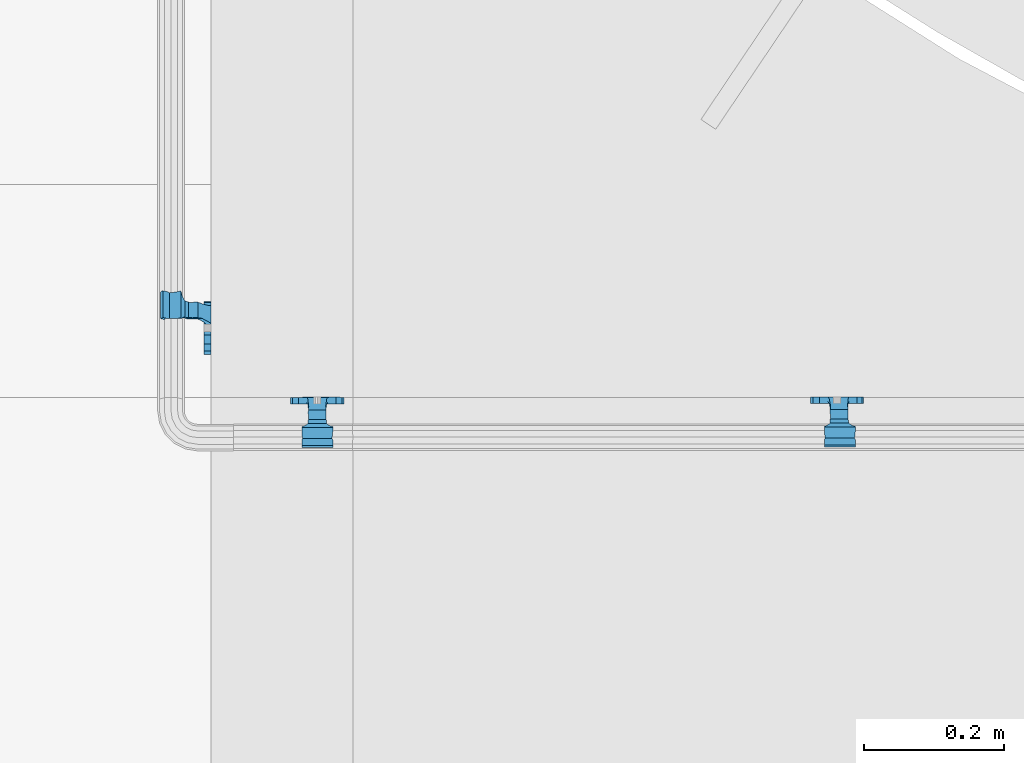
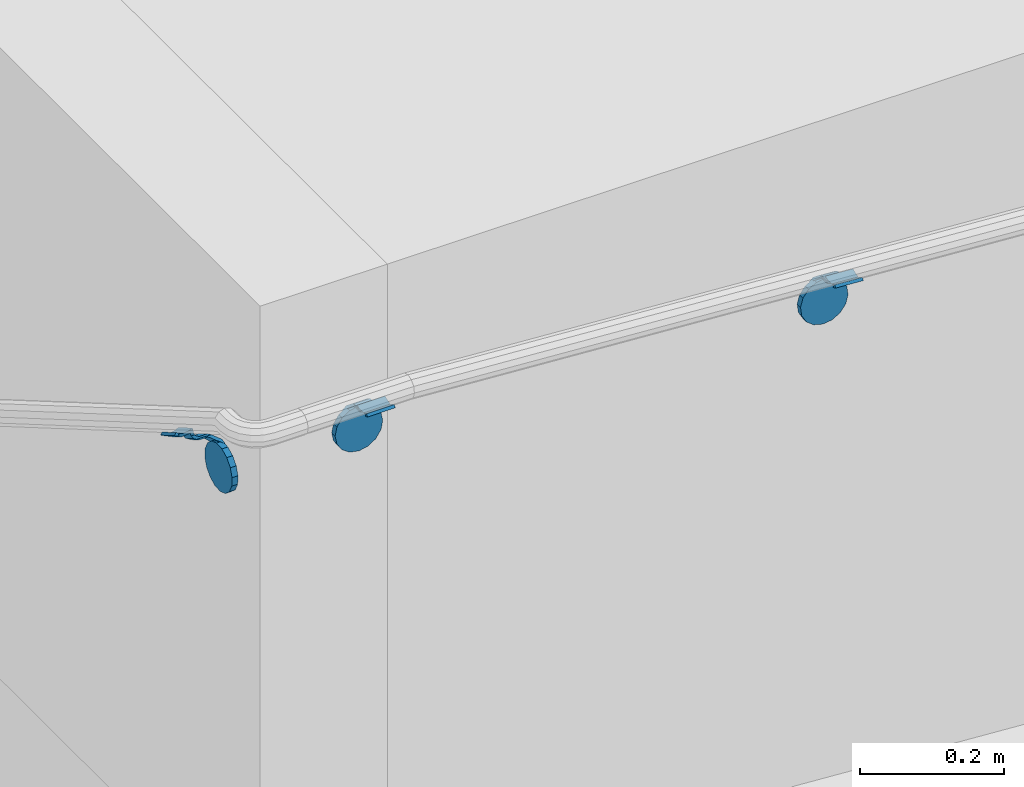
# One storey, part 458 of 975: 3 beams.
"""IFC2X3 building model written with IfcOpenShell, lengths in millimetres."""

from ifc_helpers import new_model, si_unit, frame, origin_with_axes, place, context, subcontext, project, spatial, faceted_brep, material, type_object, element, save


model = new_model("IFC2X3")

# Units and contexts
model_context = context("Model", 3, precision=1e-05, world=origin_with_axes())
body_context = subcontext(model_context, "Body", "Model", "MODEL_VIEW")
ifc_project = project(units=[si_unit("LENGTHUNIT", "METRE", prefix="MILLI"), si_unit("AREAUNIT", "SQUARE_METRE"), si_unit("VOLUMEUNIT", "CUBIC_METRE"), si_unit("MASSUNIT", "GRAM", prefix="KILO"), si_unit("TIMEUNIT", "SECOND"), si_unit("PLANEANGLEUNIT", "RADIAN"), si_unit("SOLIDANGLEUNIT", "STERADIAN"), si_unit("THERMODYNAMICTEMPERATUREUNIT", "DEGREE_CELSIUS"), si_unit("LUMINOUSINTENSITYUNIT", "LUMEN")], contexts=[model_context])

# Site, building, storey
site_placement = place(None, origin_with_axes())
site = spatial("IfcSite", under=ifc_project, at=site_placement, CompositionType="ELEMENT")
building_placement = place(site_placement, origin_with_axes())
building = spatial("IfcBuilding", under=site, at=building_placement, Name="Undefined", CompositionType="ELEMENT")
storey_placement = place(building_placement, origin_with_axes())
storey = spatial("IfcBuildingStorey", under=building, at=storey_placement, Name="Undefined", CompositionType="ELEMENT", Elevation=0.0)

# Beams
ifc_material = material(Name="STEEL/A36")
beam_type = type_object("IfcBeamType", PredefinedType="NOTDEFINED")
beam_1_placement = place(storey_placement, frame((31940.502546356, -314.324788467751, 1879.62058813558), z_axis=(0.999999955697456, 0.000267209998025066, -0.000131163650922872), x_axis=(-0.000267362000091947, 0.999999306156933, -0.00114725900017339)))
element("IfcBeam", 1, at=beam_1_placement, inside=storey, type_object=beam_type, material=ifc_material, Name="WALL BRACKET", context=body_context, shape_type="Brep", body=[
    faceted_brep([(-1.09139364212751e-11, -35.1998101886752, 14.5802387730655), (0.0, -26.940768363208, 26.9407683632162), (1.2732925824821e-11, -14.5802387731151, 35.1998101887366), (0.0, 0.0, 38.0999984741211), (3.27418092638254e-11, 14.5802387730973, 35.1998101888166), (3.45607986673713e-11, 26.9407683631939, 26.9407683633472), (3.27418092638254e-11, 35.1998101886679, 14.5802387732328), (2.36468622460961e-11, 38.0999999999908, 8.73114913702011e-11), (1.45519152283669e-11, 35.1998101886752, -14.5802387730655), (1.81898940354586e-12, 26.9407683632071, -26.9407683632162), (-1.09139364212751e-11, 14.5802387731146, -35.1998101887511), (0.0, 0.0, -38.0999984741211), (-2.91038304567337e-11, -14.5802387730978, -35.1998101888239), (-3.27418092638254e-11, -26.9407683631948, -26.9407683633617), (-3.09228198602796e-11, -35.1998101886688, -14.5802387732401), (-2.36468622460961e-11, -38.0999999999917, -9.45874489843845e-11), (9.52499999999407, 35.4440469783465, 13.3523775149006), (9.52500000001783, 38.099999999989, 1.23691279441118e-10), (5.45819490078651, 35.1998101886775, 14.58023877304), (5.15915812204861, 35.4440469814256, 13.3523774994246), (5.15916016817869, 35.4440461871586, -13.3523814925829), (5.45819607316758, 35.1998101886757, -14.5802387731565), (9.52499999563867, 35.4440461839649, -13.352381508641), (9.52499999999338, 33.7468954266617, -16.754679378646), (9.52499999999418, 26.9407683632057, -26.9407683631944), (7.23710514487385, 33.7468954167059, -16.7546793935435), (9.52499999997963, 14.5802387731133, -35.199810188722), (9.52499999996871, 7.73070496506989e-12, -38.1000000000931), (9.52499999996326, -14.5802387730996, -35.1998101888021), (9.52499999995962, -26.9407683631966, -26.9407683633399), (9.5249999999578, -35.1998101886768, -14.5802387731064), (9.52499999997235, -38.0999999999935, -7.27595761418343e-11), (9.52499999988504, -35.1998101886779, 14.5802387731401), (9.52499999999418, -26.9407683632098, 26.940768363238), (9.52500000000691, -14.5802387731169, 35.1998101887584), (9.52500000001783, -1.13686837721616e-11, 38.1000000001295), (9.5250000000251, 14.580238773096, 35.1998101888312), (9.52500000002692, 26.9407683631925, 26.9407683633617), (7.23710629084189, 33.7468933804012, 16.7546824409801), (9.52500001802099, 33.74689339, 16.7546824266137), (4.12737783423069, 36.2867482851609, 11.6630037101459), (9.52500001480979, 36.2867482910076, 11.6630037099276), (1.9072828969438, 38.0999998001848, -4.3824766180478e-06), (9.43529109937867, 38.0999998083389, -4.38277129433118e-06), (4.12738199474541, 36.2867456530334, -11.6630120660157), (9.52499999713365, 36.2867456588801, -11.6630120662267), (9.52499998931302, 31.8782691818908, -20.5007361535354), (1.90728516843444, 38.0999984362613, -14.9620414784949), (9.43529504267332, 38.0999984471014, -14.9620414798228), (9.52499998867484, 31.8782692100656, -21.3428983101403), (-0.974480980704527, 40.4536660864392, -13.6176374922397), (6.55352889353486, 40.4536660972792, -13.617637493564), (-3.23293929398841, 48.4467136552532, -12.2071016444133), (-3.86099316375032, 48.9596734302611, -12.3332393299024), (-3.86099415506237, 48.9596734359397, 12.1506042690053), (-3.23294234398753, 48.4467162038179, 12.0244673261113), (6.55352388489973, 40.4536689343606, 13.4350048968336), (9.4352891744017, 38.1000015670843, 14.7794093900302), (-8.88876894391092, 51.462646060533, -12.9487245784876), (-14.5044020842531, 51.5524567377918, -12.9708091785214), (-14.5044031272276, 51.5524567437842, 12.788173508583), (-8.88876998507754, 51.4626460665079, 12.7660889411018), (-16.4483770195459, 51.1442726592504, -12.8704360163174), (-16.4483780543928, 51.1442726651987, 12.6878004343525), (-22.5793182144077, 51.3711360271759, -12.9262221073186), (-22.5793192537777, 51.3711360331463, 12.7435864607032), (-27.8885284154861, 54.4455780358899, -13.6822326528272), (-27.8885295160832, 54.4455780422152, 13.4995963000001), (-28.6196515649072, 55.6169452716154, -13.9702738582564), (-31.1370083013608, 59.6501226213948, -17.5950925222933), (-31.1370097188383, 59.6501226295447, 17.4124524185645), (-28.6196545294583, 55.616948227025, 13.7876379643458), (-33.6296792490059, 67.324805151891, -22.2250062266612), (-32.8101722890036, 64.8016260361878, -22.2250061928717), (-39.3161821982224, 64.9509398614337, -22.2250064563596), (-33.6296810489844, 67.3248051619378, 22.2249937734341), (-39.3127719838823, 64.95236112884, 22.2249935438595), (-32.8101756191698, 64.8016307577993, 22.2249938072164), (-49.8281982508399, 63.7590297560901, -21.2879733583577), (-49.8281999673757, 63.7590297658239, 21.1053316176076), (-62.537662592724, 64.8016282183019, -22.2250073966388), (-62.5376643923654, 64.8016282284259, 22.2249926034456), (-59.3629825026719, 68.3509998487543, 22.2249927311568), (-59.3629807030303, 68.3509998386305, -22.2250072689349), (-56.0005505059879, 61.6533412669896, 22.2249928688907), (-56.0009816237271, 61.6535489521873, 19.2130312653135), (-56.0009816302269, 64.8016307505561, 22.0423689734525), (-51.9930603186979, 64.8016307660225, 22.2249930304133), (-51.9930486616773, 64.8016260085653, -22.2250069696784), (-56.000981616694, 61.6535497473442, -22.2250071312228), (-56.0009816212363, 64.8016260027941, -22.2250068759422), (-56.0009816161877, 61.6535496925769, -19.3956728877092), (-50.6240356350016, 59.0640018412871, -17.0683164176735), (-50.6240370098228, 59.0640018490833, 16.8856764812081), (-37.4851004069614, 60.555058921409, -18.4084041452843), (-37.4851018904596, 60.555058929803, 18.2257636742615), (-36.5628425975134, 60.9400579463424, -18.7544220673662), (-36.5628441090176, 60.9400579547794, 18.5717814508498), (-35.6661101826384, 58.1791091500552, -16.2730189810172), (-35.6661114930633, 58.1791091575863, 16.0903794298065), (-34.0669073739811, 55.616948225869, 13.7876379531408), (-34.0669044052501, 55.6169452637716, -13.9702738572996), (-31.199578137138, 51.0230652214489, -12.8406309028251), (-31.1995791695818, 51.0230652273826, 12.6579953160217), (-13.5258453474495, 46.8920843628518, -12.4814476045976), (-10.0158535806146, 46.8359491542703, -12.491353805628), (-10.0158545847443, 46.8359491600327, 12.308720278641), (-13.5258463507973, 46.8920843686235, 12.298814059428), (-15.4698202757649, 46.4839002842855, -12.5534799881534), (-15.469821284944, 46.4839002900824, 12.3708465294185), (-23.8996230795056, 46.7958284847284, -12.4984339079674), (-23.8996240842331, 46.7958284904998, 12.3158003666576), (-26.7505131823156, 48.4467136213889, -12.207101640266), (-26.7505186046602, 48.4467161988273, 12.0244672777189), (-6.87329577845111, 45.2714927334573, -12.7674339683217), (-6.87329680492121, 45.2714927393397, 12.584800790275), (-0.974485553301008, 40.4536689327629, 13.4350048813394), (1.90728014135857, 38.100001565487, 14.7794093745397), (9.52500002100476, 31.8782677827221, 21.320715892205), (9.52500002038346, 31.878267810155, 20.5007393728483)], [[[0, 1, 2, 3, 4, 5, 6, 7, 8, 9, 10, 11, 12, 13, 14, 15]], [[16, 17, 7, 6, 18, 19]], [[20, 21, 8, 7, 17, 22]], [[23, 24, 9, 8, 21, 25]], [[10, 9, 24, 26]], [[11, 10, 26, 27]], [[12, 11, 27, 28]], [[13, 12, 28, 29]], [[14, 13, 29, 30]], [[15, 14, 30, 31]], [[0, 15, 31, 32]], [[1, 0, 32, 33]], [[2, 1, 33, 34]], [[3, 2, 34, 35]], [[4, 3, 35, 36]], [[5, 4, 36, 37]], [[38, 18, 6, 5, 37, 39]], [[39, 37, 36, 35, 34, 33, 32, 31, 30, 29, 28, 27, 26, 24, 23, 22, 17, 16]], [[40, 41, 16, 19]], [[40, 42, 43, 41]], [[42, 44, 45, 43]], [[46, 23, 25]], [[47, 48, 49]], [[48, 47, 50, 51]], [[51, 52, 53, 54, 55, 56, 57, 48]], [[58, 59, 60, 61]], [[59, 62, 63, 60]], [[62, 64, 65, 63]], [[64, 66, 67, 65]], [[66, 68, 69, 70, 71, 67]], [[72, 73, 74]], [[75, 76, 77]], [[74, 76, 75, 72]], [[74, 78, 79, 76]], [[80, 81, 82, 83]], [[84, 85, 86]], [[82, 81, 84, 86, 87]], [[78, 88, 83, 82, 87, 79]], [[89, 80, 83, 88, 90]], [[89, 90, 91]], [[84, 81, 80, 89, 91, 92, 93, 85]], [[92, 94, 95, 93]], [[94, 96, 97, 95]], [[96, 98, 99, 97]], [[70, 77, 76, 79, 87, 86, 85, 93, 95, 97, 99, 100, 71]], [[69, 73, 72, 75, 77, 70]], [[68, 101, 98, 96, 94, 92, 91, 90, 88, 78, 74, 73, 69]], [[99, 98, 101, 102, 103, 100]], [[104, 105, 106, 107]], [[108, 104, 107, 109]], [[110, 108, 109, 111]], [[103, 102, 112, 110, 111, 113]], [[54, 61, 60, 63, 65, 67, 71, 100, 103, 113, 55]], [[53, 58, 61, 54]], [[52, 112, 102, 101, 68, 66, 64, 62, 59, 58, 53]], [[51, 50, 114, 105, 104, 108, 110, 112, 52]], [[105, 114, 115, 106]], [[55, 113, 111, 109, 107, 106, 115, 116, 56]], [[56, 116, 117, 57]], [[117, 118, 57]], [[39, 16, 41, 43, 45, 22, 23, 46, 49, 48, 57, 118, 119]], [[119, 38, 39]], [[119, 118, 117, 116, 115, 114, 50, 47, 49, 46, 25, 21, 20, 44, 42, 40, 19, 18, 38]], [[45, 44, 20, 22]]]),
])
beam_2_placement = place(storey_placement, frame((32684.7119659092, -313.696406798522, 1833.70106232672), z_axis=(0.997825118892356, 0.000267209998910687, -0.0659163159337137), x_axis=(-0.000342255999979527, 0.999999306150399, -0.00112719100017556)))
element("IfcBeam", 2, at=beam_2_placement, inside=storey, type_object=beam_type, material=ifc_material, Name="WALL BRACKET", context=body_context, shape_type="Brep", body=[
    faceted_brep([(-1.09139364212751e-11, -35.1998101886752, 14.5802387730655), (0.0, -26.940768363208, 26.9407683632162), (1.2732925824821e-11, -14.5802387731151, 35.1998101887366), (0.0, 0.0, 38.0999984741211), (3.27418092638254e-11, 14.5802387730973, 35.1998101888166), (3.45607986673713e-11, 26.9407683631939, 26.9407683633472), (3.27418092638254e-11, 35.1998101886679, 14.5802387732328), (2.36468622460961e-11, 38.0999999999908, 8.73114913702011e-11), (1.45519152283669e-11, 35.1998101886752, -14.5802387730655), (1.81898940354586e-12, 26.9407683632071, -26.9407683632162), (-1.09139364212751e-11, 14.5802387731146, -35.1998101887511), (0.0, 0.0, -38.0999984741211), (-2.91038304567337e-11, -14.5802387730978, -35.1998101888239), (-3.27418092638254e-11, -26.9407683631948, -26.9407683633617), (-3.09228198602796e-11, -35.1998101886688, -14.5802387732401), (-2.36468622460961e-11, -38.0999999999917, -9.45874489843845e-11), (9.52499999999407, 35.4440469783465, 13.3523775149006), (9.52500000001783, 38.099999999989, 1.23691279441118e-10), (5.45819490078651, 35.1998101886775, 14.58023877304), (5.15915812204861, 35.4440469814256, 13.3523774994246), (5.15916016817869, 35.4440461871586, -13.3523814925829), (5.45819607316758, 35.1998101886757, -14.5802387731565), (9.52499999563867, 35.4440461839649, -13.352381508641), (9.52499999999338, 33.7468954266617, -16.754679378646), (9.52499999999418, 26.9407683632057, -26.9407683631944), (7.23710514487385, 33.7468954167059, -16.7546793935435), (9.52499999997963, 14.5802387731133, -35.199810188722), (9.52499999996871, 7.73070496506989e-12, -38.1000000000931), (9.52499999996326, -14.5802387730996, -35.1998101888021), (9.52499999995962, -26.9407683631966, -26.9407683633399), (9.5249999999578, -35.1998101886768, -14.5802387731064), (9.52499999997235, -38.0999999999935, -7.27595761418343e-11), (9.52499999988504, -35.1998101886779, 14.5802387731401), (9.52499999999418, -26.9407683632098, 26.940768363238), (9.52500000000691, -14.5802387731169, 35.1998101887584), (9.52500000001783, -1.13686837721616e-11, 38.1000000001295), (9.5250000000251, 14.580238773096, 35.1998101888312), (9.52500000002692, 26.9407683631925, 26.9407683633617), (7.23710629084189, 33.7468933804012, 16.7546824409801), (9.52500001802099, 33.74689339, 16.7546824266137), (4.12737783423069, 36.2867482851609, 11.6630037101459), (9.52500001480979, 36.2867482910076, 11.6630037099276), (1.9072828969438, 38.0999998001848, -4.3824766180478e-06), (9.43529109937867, 38.0999998083389, -4.38277129433118e-06), (4.12738199474541, 36.2867456530334, -11.6630120660157), (9.52499999713365, 36.2867456588801, -11.6630120662267), (9.52499998931302, 31.8782691818908, -20.5007361535354), (1.90728516843444, 38.0999984362613, -14.9620414784949), (9.43529504267332, 38.0999984471014, -14.9620414798228), (9.52499998867484, 31.8782692100656, -21.3428983101403), (-0.974480980704527, 40.4536660864392, -13.6176374922397), (6.55352889353486, 40.4536660972792, -13.617637493564), (-3.23293929398841, 48.4467136552532, -12.2071016444133), (-3.86099316375032, 48.9596734302611, -12.3332393299024), (-3.86099415506237, 48.9596734359397, 12.1506042690053), (-3.23294234398753, 48.4467162038179, 12.0244673261113), (6.55352388489973, 40.4536689343606, 13.4350048968336), (9.4352891744017, 38.1000015670843, 14.7794093900302), (-8.88876894391092, 51.462646060533, -12.9487245784876), (-14.5044020842531, 51.5524567377918, -12.9708091785214), (-14.5044031272276, 51.5524567437842, 12.788173508583), (-8.88876998507754, 51.4626460665079, 12.7660889411018), (-16.4483770195459, 51.1442726592504, -12.8704360163174), (-16.4483780543928, 51.1442726651987, 12.6878004343525), (-22.5793182144077, 51.3711360271759, -12.9262221073186), (-22.5793192537777, 51.3711360331463, 12.7435864607032), (-27.8885284154861, 54.4455780358899, -13.6822326528272), (-27.8885295160832, 54.4455780422152, 13.4995963000001), (-28.6196515649072, 55.6169452716154, -13.9702738582564), (-31.1370083013608, 59.6501226213948, -17.5950925222933), (-31.1370097188383, 59.6501226295447, 17.4124524185645), (-28.6196545294583, 55.616948227025, 13.7876379643458), (-33.6296792490059, 67.324805151891, -22.2250062266612), (-32.8101722890036, 64.8016260361878, -22.2250061928717), (-39.3161821982224, 64.9509398614337, -22.2250064563596), (-33.6296810489844, 67.3248051619378, 22.2249937734341), (-39.3127719838823, 64.95236112884, 22.2249935438595), (-32.8101756191698, 64.8016307577993, 22.2249938072164), (-49.8281982508399, 63.7590297560901, -21.2879733583577), (-49.8281999673757, 63.7590297658239, 21.1053316176076), (-62.537662592724, 64.8016282183019, -22.2250073966388), (-62.5376643923654, 64.8016282284259, 22.2249926034456), (-59.3629825026719, 68.3509998487543, 22.2249927311568), (-59.3629807030303, 68.3509998386305, -22.2250072689349), (-56.0005505059879, 61.6533412669896, 22.2249928688907), (-56.0009816237271, 61.6535489521873, 19.2130312653135), (-56.0009816302269, 64.8016307505561, 22.0423689734525), (-51.9930603186979, 64.8016307660225, 22.2249930304133), (-51.9930486616773, 64.8016260085653, -22.2250069696784), (-56.000981616694, 61.6535497473442, -22.2250071312228), (-56.0009816212363, 64.8016260027941, -22.2250068759422), (-56.0009816161877, 61.6535496925769, -19.3956728877092), (-50.6240356350016, 59.0640018412871, -17.0683164176735), (-50.6240370098228, 59.0640018490833, 16.8856764812081), (-37.4851004069614, 60.555058921409, -18.4084041452843), (-37.4851018904596, 60.555058929803, 18.2257636742615), (-36.5628425975134, 60.9400579463424, -18.7544220673662), (-36.5628441090176, 60.9400579547794, 18.5717814508498), (-35.6661101826384, 58.1791091500552, -16.2730189810172), (-35.6661114930633, 58.1791091575863, 16.0903794298065), (-34.0669073739811, 55.616948225869, 13.7876379531408), (-34.0669044052501, 55.6169452637716, -13.9702738572996), (-31.199578137138, 51.0230652214489, -12.8406309028251), (-31.1995791695818, 51.0230652273826, 12.6579953160217), (-13.5258453474495, 46.8920843628518, -12.4814476045976), (-10.0158535806146, 46.8359491542703, -12.491353805628), (-10.0158545847443, 46.8359491600327, 12.308720278641), (-13.5258463507973, 46.8920843686235, 12.298814059428), (-15.4698202757649, 46.4839002842855, -12.5534799881534), (-15.469821284944, 46.4839002900824, 12.3708465294185), (-23.8996230795056, 46.7958284847284, -12.4984339079674), (-23.8996240842331, 46.7958284904998, 12.3158003666576), (-26.7505131823156, 48.4467136213889, -12.207101640266), (-26.7505186046602, 48.4467161988273, 12.0244672777189), (-6.87329577845111, 45.2714927334573, -12.7674339683217), (-6.87329680492121, 45.2714927393397, 12.584800790275), (-0.974485553301008, 40.4536689327629, 13.4350048813394), (1.90728014135857, 38.100001565487, 14.7794093745397), (9.52500002100476, 31.8782677827221, 21.320715892205), (9.52500002038346, 31.878267810155, 20.5007393728483)], [[[0, 1, 2, 3, 4, 5, 6, 7, 8, 9, 10, 11, 12, 13, 14, 15]], [[16, 17, 7, 6, 18, 19]], [[20, 21, 8, 7, 17, 22]], [[23, 24, 9, 8, 21, 25]], [[10, 9, 24, 26]], [[11, 10, 26, 27]], [[12, 11, 27, 28]], [[13, 12, 28, 29]], [[14, 13, 29, 30]], [[15, 14, 30, 31]], [[0, 15, 31, 32]], [[1, 0, 32, 33]], [[2, 1, 33, 34]], [[3, 2, 34, 35]], [[4, 3, 35, 36]], [[5, 4, 36, 37]], [[38, 18, 6, 5, 37, 39]], [[39, 37, 36, 35, 34, 33, 32, 31, 30, 29, 28, 27, 26, 24, 23, 22, 17, 16]], [[40, 41, 16, 19]], [[40, 42, 43, 41]], [[42, 44, 45, 43]], [[46, 23, 25]], [[47, 48, 49]], [[48, 47, 50, 51]], [[51, 52, 53, 54, 55, 56, 57, 48]], [[58, 59, 60, 61]], [[59, 62, 63, 60]], [[62, 64, 65, 63]], [[64, 66, 67, 65]], [[66, 68, 69, 70, 71, 67]], [[72, 73, 74]], [[75, 76, 77]], [[74, 76, 75, 72]], [[74, 78, 79, 76]], [[80, 81, 82, 83]], [[84, 85, 86]], [[82, 81, 84, 86, 87]], [[78, 88, 83, 82, 87, 79]], [[89, 80, 83, 88, 90]], [[89, 90, 91]], [[84, 81, 80, 89, 91, 92, 93, 85]], [[92, 94, 95, 93]], [[94, 96, 97, 95]], [[96, 98, 99, 97]], [[70, 77, 76, 79, 87, 86, 85, 93, 95, 97, 99, 100, 71]], [[69, 73, 72, 75, 77, 70]], [[68, 101, 98, 96, 94, 92, 91, 90, 88, 78, 74, 73, 69]], [[99, 98, 101, 102, 103, 100]], [[104, 105, 106, 107]], [[108, 104, 107, 109]], [[110, 108, 109, 111]], [[103, 102, 112, 110, 111, 113]], [[54, 61, 60, 63, 65, 67, 71, 100, 103, 113, 55]], [[53, 58, 61, 54]], [[52, 112, 102, 101, 68, 66, 64, 62, 59, 58, 53]], [[51, 50, 114, 105, 104, 108, 110, 112, 52]], [[105, 114, 115, 106]], [[55, 113, 111, 109, 107, 106, 115, 116, 56]], [[56, 116, 117, 57]], [[117, 118, 57]], [[39, 16, 41, 43, 45, 22, 23, 46, 49, 48, 57, 118, 119]], [[119, 38, 39]], [[119, 118, 117, 116, 115, 114, 50, 47, 49, 46, 25, 21, 20, 44, 42, 40, 19, 18, 38]], [[45, 44, 20, 22]]]),
])
beam_3_placement = place(storey_placement, frame((31778.574969517, -205.723611266918, 1804.69680845854), z_axis=(0.0, -0.863778825965781, 0.50387115398004), x_axis=(1.0, 0.0, 0.0)))
element("IfcBeam", 3, at=beam_3_placement, inside=storey, type_object=beam_type, material=ifc_material, Name="WALL BRACKET", context=body_context, shape_type="Brep", body=[
    faceted_brep([(-1.09139364212751e-11, -35.1998101886752, 14.5802387730655), (0.0, -26.940768363208, 26.9407683632162), (1.2732925824821e-11, -14.5802387731151, 35.1998101887366), (0.0, 0.0, 38.0999984741211), (3.27418092638254e-11, 14.5802387730973, 35.1998101888166), (3.45607986673713e-11, 26.9407683631939, 26.9407683633472), (3.27418092638254e-11, 35.1998101886679, 14.5802387732328), (2.36468622460961e-11, 38.0999999999908, 8.73114913702011e-11), (1.45519152283669e-11, 35.1998101886752, -14.5802387730655), (1.81898940354586e-12, 26.9407683632071, -26.9407683632162), (-1.09139364212751e-11, 14.5802387731146, -35.1998101887511), (0.0, 0.0, -38.0999984741211), (-2.91038304567337e-11, -14.5802387730978, -35.1998101888239), (-3.27418092638254e-11, -26.9407683631948, -26.9407683633617), (-3.09228198602796e-11, -35.1998101886688, -14.5802387732401), (-2.36468622460961e-11, -38.0999999999917, -9.45874489843845e-11), (9.52499999999407, 35.4440469783465, 13.3523775149006), (9.52500000001783, 38.099999999989, 1.23691279441118e-10), (5.45819490078651, 35.1998101886775, 14.58023877304), (5.15915812204861, 35.4440469814256, 13.3523774994246), (5.15916016817869, 35.4440461871586, -13.3523814925829), (5.45819607316758, 35.1998101886757, -14.5802387731565), (9.52499999563867, 35.4440461839649, -13.352381508641), (9.52499999999338, 33.7468954266617, -16.754679378646), (9.52499999999418, 26.9407683632057, -26.9407683631944), (7.23710514487385, 33.7468954167059, -16.7546793935435), (9.52499999997963, 14.5802387731133, -35.199810188722), (9.52499999996871, 7.73070496506989e-12, -38.1000000000931), (9.52499999996326, -14.5802387730996, -35.1998101888021), (9.52499999995962, -26.9407683631966, -26.9407683633399), (9.5249999999578, -35.1998101886768, -14.5802387731064), (9.52499999997235, -38.0999999999935, -7.27595761418343e-11), (9.52499999988504, -35.1998101886779, 14.5802387731401), (9.52499999999418, -26.9407683632098, 26.940768363238), (9.52500000000691, -14.5802387731169, 35.1998101887584), (9.52500000001783, -1.13686837721616e-11, 38.1000000001295), (9.5250000000251, 14.580238773096, 35.1998101888312), (9.52500000002692, 26.9407683631925, 26.9407683633617), (7.23710629084189, 33.7468933804012, 16.7546824409801), (9.52500001802099, 33.74689339, 16.7546824266137), (4.12737783423069, 36.2867482851609, 11.6630037101459), (9.52500001480979, 36.2867482910076, 11.6630037099276), (1.9072828969438, 38.0999998001848, -4.3824766180478e-06), (9.43529109937867, 38.0999998083389, -4.38277129433118e-06), (4.12738199474541, 36.2867456530334, -11.6630120660157), (9.52499999713365, 36.2867456588801, -11.6630120662267), (9.52499998931302, 31.8782691818908, -20.5007361535354), (1.90728516843444, 38.0999984362613, -14.9620414784949), (9.43529504267332, 38.0999984471014, -14.9620414798228), (9.52499998867484, 31.8782692100656, -21.3428983101403), (-0.974480980704527, 40.4536660864392, -13.6176374922397), (6.55352889353486, 40.4536660972792, -13.617637493564), (-3.23293929398841, 48.4467136552532, -12.2071016444133), (-3.86099316375032, 48.9596734302611, -12.3332393299024), (-3.86099415506237, 48.9596734359397, 12.1506042690053), (-3.23294234398753, 48.4467162038179, 12.0244673261113), (6.55352388489973, 40.4536689343606, 13.4350048968336), (9.4352891744017, 38.1000015670843, 14.7794093900302), (-8.88876894391092, 51.462646060533, -12.9487245784876), (-14.5044020842531, 51.5524567377918, -12.9708091785214), (-14.5044031272276, 51.5524567437842, 12.788173508583), (-8.88876998507754, 51.4626460665079, 12.7660889411018), (-16.4483770195459, 51.1442726592504, -12.8704360163174), (-16.4483780543928, 51.1442726651987, 12.6878004343525), (-22.5793182144077, 51.3711360271759, -12.9262221073186), (-22.5793192537777, 51.3711360331463, 12.7435864607032), (-27.8885284154861, 54.4455780358899, -13.6822326528272), (-27.8885295160832, 54.4455780422152, 13.4995963000001), (-28.6196515649072, 55.6169452716154, -13.9702738582564), (-31.1370083013608, 59.6501226213948, -17.5950925222933), (-31.1370097188383, 59.6501226295447, 17.4124524185645), (-28.6196545294583, 55.616948227025, 13.7876379643458), (-33.6296792490059, 67.324805151891, -22.2250062266612), (-32.8101722890036, 64.8016260361878, -22.2250061928717), (-39.3161821982224, 64.9509398614337, -22.2250064563596), (-33.6296810489844, 67.3248051619378, 22.2249937734341), (-39.3127719838823, 64.95236112884, 22.2249935438595), (-32.8101756191698, 64.8016307577993, 22.2249938072164), (-49.8281982508399, 63.7590297560901, -21.2879733583577), (-49.8281999673757, 63.7590297658239, 21.1053316176076), (-62.537662592724, 64.8016282183019, -22.2250073966388), (-62.5376643923654, 64.8016282284259, 22.2249926034456), (-59.3629825026719, 68.3509998487543, 22.2249927311568), (-59.3629807030303, 68.3509998386305, -22.2250072689349), (-56.0005505059879, 61.6533412669896, 22.2249928688907), (-56.0009816237271, 61.6535489521873, 19.2130312653135), (-56.0009816302269, 64.8016307505561, 22.0423689734525), (-51.9930603186979, 64.8016307660225, 22.2249930304133), (-51.9930486616773, 64.8016260085653, -22.2250069696784), (-56.000981616694, 61.6535497473442, -22.2250071312228), (-56.0009816212363, 64.8016260027941, -22.2250068759422), (-56.0009816161877, 61.6535496925769, -19.3956728877092), (-50.6240356350016, 59.0640018412871, -17.0683164176735), (-50.6240370098228, 59.0640018490833, 16.8856764812081), (-37.4851004069614, 60.555058921409, -18.4084041452843), (-37.4851018904596, 60.555058929803, 18.2257636742615), (-36.5628425975134, 60.9400579463424, -18.7544220673662), (-36.5628441090176, 60.9400579547794, 18.5717814508498), (-35.6661101826384, 58.1791091500552, -16.2730189810172), (-35.6661114930633, 58.1791091575863, 16.0903794298065), (-34.0669073739811, 55.616948225869, 13.7876379531408), (-34.0669044052501, 55.6169452637716, -13.9702738572996), (-31.199578137138, 51.0230652214489, -12.8406309028251), (-31.1995791695818, 51.0230652273826, 12.6579953160217), (-13.5258453474495, 46.8920843628518, -12.4814476045976), (-10.0158535806146, 46.8359491542703, -12.491353805628), (-10.0158545847443, 46.8359491600327, 12.308720278641), (-13.5258463507973, 46.8920843686235, 12.298814059428), (-15.4698202757649, 46.4839002842855, -12.5534799881534), (-15.469821284944, 46.4839002900824, 12.3708465294185), (-23.8996230795056, 46.7958284847284, -12.4984339079674), (-23.8996240842331, 46.7958284904998, 12.3158003666576), (-26.7505131823156, 48.4467136213889, -12.207101640266), (-26.7505186046602, 48.4467161988273, 12.0244672777189), (-6.87329577845111, 45.2714927334573, -12.7674339683217), (-6.87329680492121, 45.2714927393397, 12.584800790275), (-0.974485553301008, 40.4536689327629, 13.4350048813394), (1.90728014135857, 38.100001565487, 14.7794093745397), (9.52500002100476, 31.8782677827221, 21.320715892205), (9.52500002038346, 31.878267810155, 20.5007393728483)], [[[0, 1, 2, 3, 4, 5, 6, 7, 8, 9, 10, 11, 12, 13, 14, 15]], [[16, 17, 7, 6, 18, 19]], [[20, 21, 8, 7, 17, 22]], [[23, 24, 9, 8, 21, 25]], [[10, 9, 24, 26]], [[11, 10, 26, 27]], [[12, 11, 27, 28]], [[13, 12, 28, 29]], [[14, 13, 29, 30]], [[15, 14, 30, 31]], [[0, 15, 31, 32]], [[1, 0, 32, 33]], [[2, 1, 33, 34]], [[3, 2, 34, 35]], [[4, 3, 35, 36]], [[5, 4, 36, 37]], [[38, 18, 6, 5, 37, 39]], [[39, 37, 36, 35, 34, 33, 32, 31, 30, 29, 28, 27, 26, 24, 23, 22, 17, 16]], [[40, 41, 16, 19]], [[40, 42, 43, 41]], [[42, 44, 45, 43]], [[46, 23, 25]], [[47, 48, 49]], [[48, 47, 50, 51]], [[51, 52, 53, 54, 55, 56, 57, 48]], [[58, 59, 60, 61]], [[59, 62, 63, 60]], [[62, 64, 65, 63]], [[64, 66, 67, 65]], [[66, 68, 69, 70, 71, 67]], [[72, 73, 74]], [[75, 76, 77]], [[74, 76, 75, 72]], [[74, 78, 79, 76]], [[80, 81, 82, 83]], [[84, 85, 86]], [[82, 81, 84, 86, 87]], [[78, 88, 83, 82, 87, 79]], [[89, 80, 83, 88, 90]], [[89, 90, 91]], [[84, 81, 80, 89, 91, 92, 93, 85]], [[92, 94, 95, 93]], [[94, 96, 97, 95]], [[96, 98, 99, 97]], [[70, 77, 76, 79, 87, 86, 85, 93, 95, 97, 99, 100, 71]], [[69, 73, 72, 75, 77, 70]], [[68, 101, 98, 96, 94, 92, 91, 90, 88, 78, 74, 73, 69]], [[99, 98, 101, 102, 103, 100]], [[104, 105, 106, 107]], [[108, 104, 107, 109]], [[110, 108, 109, 111]], [[103, 102, 112, 110, 111, 113]], [[54, 61, 60, 63, 65, 67, 71, 100, 103, 113, 55]], [[53, 58, 61, 54]], [[52, 112, 102, 101, 68, 66, 64, 62, 59, 58, 53]], [[51, 50, 114, 105, 104, 108, 110, 112, 52]], [[105, 114, 115, 106]], [[55, 113, 111, 109, 107, 106, 115, 116, 56]], [[56, 116, 117, 57]], [[117, 118, 57]], [[39, 16, 41, 43, 45, 22, 23, 46, 49, 48, 57, 118, 119]], [[119, 38, 39]], [[119, 118, 117, 116, 115, 114, 50, 47, 49, 46, 25, 21, 20, 44, 42, 40, 19, 18, 38]], [[45, 44, 20, 22]]]),
])

save(model, "model.ifc")
